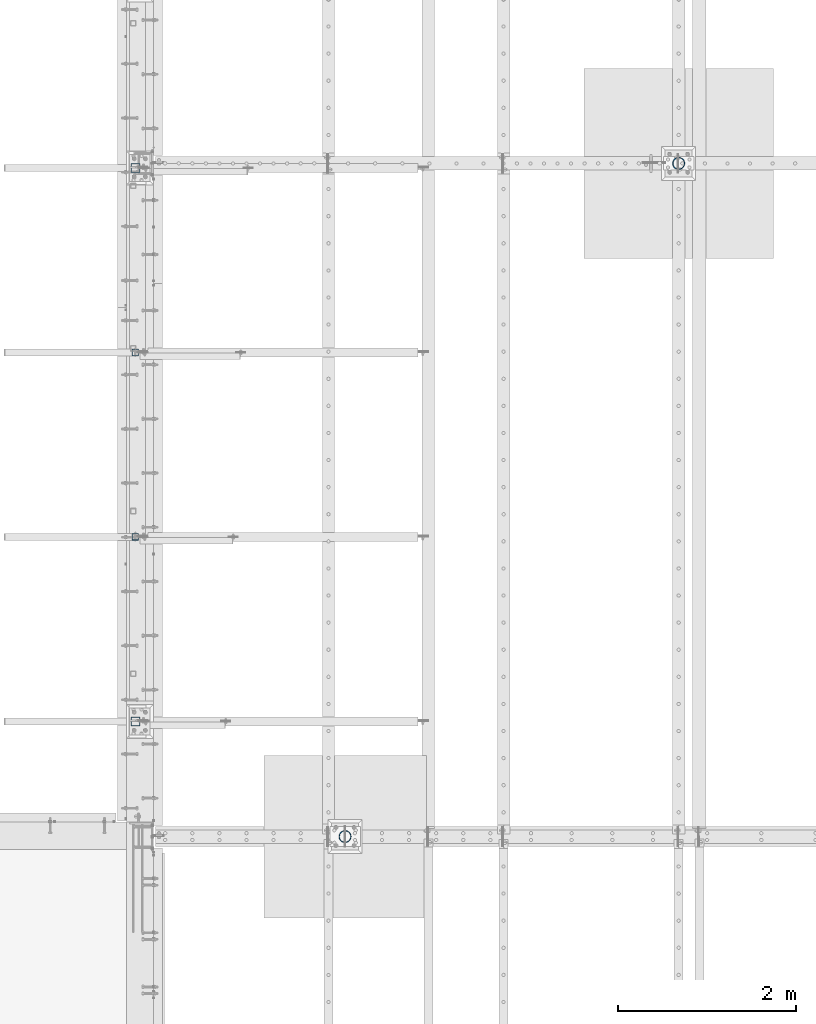
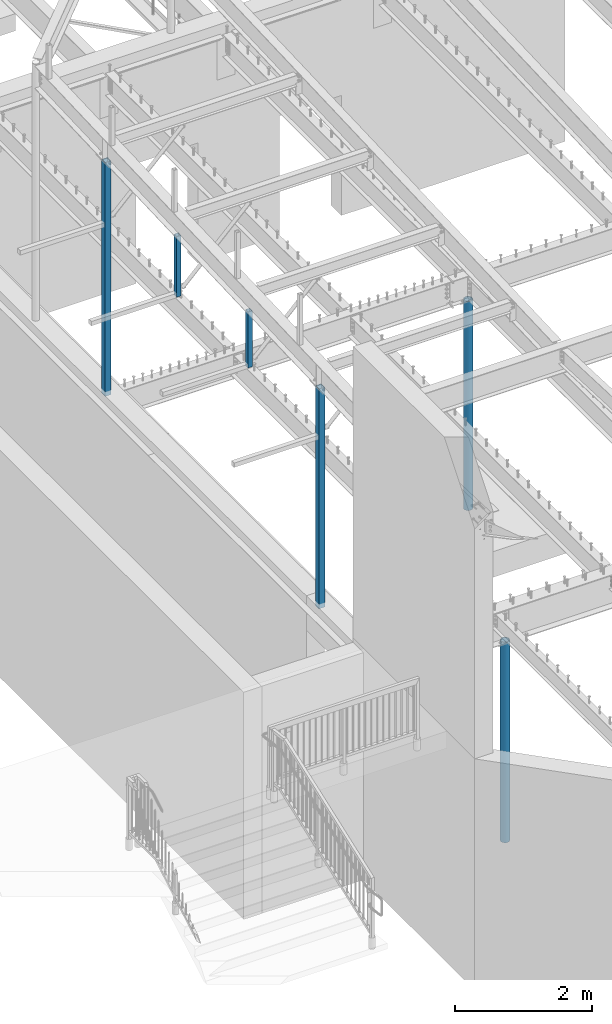
# One storey, part 121 of 975: 6 columns.
"""IFC2X3 building model written with IfcOpenShell, lengths in millimetres."""

from ifc_helpers import new_model, si_unit, frame, origin_with_axes, place, context, subcontext, project, spatial, faceted_brep, material, type_object, element, save


model = new_model("IFC2X3")

# Units and contexts
model_context = context("Model", 3, precision=1e-05, world=origin_with_axes())
body_context = subcontext(model_context, "Body", "Model", "MODEL_VIEW")
ifc_project = project(units=[si_unit("LENGTHUNIT", "METRE", prefix="MILLI"), si_unit("AREAUNIT", "SQUARE_METRE"), si_unit("VOLUMEUNIT", "CUBIC_METRE"), si_unit("MASSUNIT", "GRAM", prefix="KILO"), si_unit("TIMEUNIT", "SECOND"), si_unit("PLANEANGLEUNIT", "RADIAN"), si_unit("SOLIDANGLEUNIT", "STERADIAN"), si_unit("THERMODYNAMICTEMPERATUREUNIT", "DEGREE_CELSIUS"), si_unit("LUMINOUSINTENSITYUNIT", "LUMEN")], contexts=[model_context])

# Site, building, storey
site_placement = place(None, origin_with_axes())
site = spatial("IfcSite", under=ifc_project, at=site_placement, CompositionType="ELEMENT")
building_placement = place(site_placement, origin_with_axes())
building = spatial("IfcBuilding", under=site, at=building_placement, Name="Undefined", CompositionType="ELEMENT")
storey_placement = place(building_placement, origin_with_axes())
storey = spatial("IfcBuildingStorey", under=building, at=storey_placement, Name="Undefined", CompositionType="ELEMENT", Elevation=0.0)

# Columns
ifc_material_1 = material()
column_type_1 = type_object("IfcColumnType", Name="HSS3X3X1/4", PredefinedType="NOTDEFINED")
column_1_placement = place(storey_placement, frame((2117.725, 9190.56666666666, 6959.6), z_axis=(1.0, 0.0, 0.0), x_axis=(0.0, 0.0, 1.0)))
element("IfcColumn", 1, at=column_1_placement, inside=storey, type_object=column_type_1, material=ifc_material_1, ObjectType="HSS3X3X1/4", context=body_context, shape_type="Brep", body=[
    faceted_brep([(6.35000000000127, -38.1000000000004, -38.0999999999999), (6.35000000000127, 38.1000000000004, -38.0999999999999), (999.106686584069, 38.1000000000004, -38.0999999999999), (1002.13967160395, -38.1000000000004, -38.0999999999999), (6.35000000000127, -38.1000000000004, 38.0999999999999), (1002.13967160395, -38.1000000000004, 38.0999999999999), (6.35000000000127, 38.1000000000004, 38.0999999999999), (999.106686584069, 38.1000000000004, 38.0999999999999), (6.35000000000127, 31.75, 31.75), (6.35000000000127, -31.75, 31.75), (6.35000000000127, -31.75, -31.75), (6.35000000000127, 31.75, -31.75), (1001.88692285229, -31.75, 31.75), (1001.88692285229, -31.75, -31.75), (999.359435335726, 31.75, -31.75), (999.359435335726, 31.75, 31.75)], [[[0, 1, 2, 3]], [[4, 0, 3, 5]], [[6, 4, 5, 7]], [[1, 6, 7, 2]], [[0, 4, 6, 1], [8, 9, 10, 11]], [[10, 9, 12, 13]], [[11, 10, 13, 14]], [[8, 11, 14, 15]], [[9, 8, 15, 12]], [[2, 7, 5, 3], [14, 13, 12, 15]]]),
])
column_2_placement = place(storey_placement, frame((2117.725, 11265.9583333333, 6959.6), z_axis=(1.0, 0.0, 0.0), x_axis=(0.0, 0.0, 1.0)))
element("IfcColumn", 2, at=column_2_placement, inside=storey, type_object=column_type_1, material=ifc_material_1, ObjectType="HSS3X3X1/4", context=body_context, shape_type="Brep", body=[
    faceted_brep([(6.35000000000127, -38.1000000000004, -38.0999999999999), (6.35000000000127, 38.1000000000004, -38.0999999999999), (1081.7134035839, 38.1000000000004, -38.0999999999999), (1084.74638860378, -38.1000000000004, -38.0999999999999), (6.35000000000127, -38.1000000000004, 38.0999999999999), (1084.74638860378, -38.1000000000004, 38.0999999999999), (6.35000000000127, 38.1000000000004, 38.0999999999999), (1081.7134035839, 38.1000000000004, 38.0999999999999), (6.35000000000127, 31.75, 31.75), (6.35000000000127, -31.75, 31.75), (6.35000000000127, -31.75, -31.75), (6.35000000000127, 31.75, -31.75), (1084.49363985213, -31.75, 31.75), (1084.49363985213, -31.75, -31.75), (1081.96615233556, 31.75, -31.75), (1081.96615233556, 31.75, 31.75)], [[[0, 1, 2, 3]], [[4, 0, 3, 5]], [[6, 4, 5, 7]], [[1, 6, 7, 2]], [[0, 4, 6, 1], [8, 9, 10, 11]], [[10, 9, 12, 13]], [[11, 10, 13, 14]], [[8, 11, 14, 15]], [[9, 8, 15, 12]], [[2, 7, 5, 3], [14, 13, 12, 15]]]),
])
column_type_2 = type_object("IfcColumnType", Name="HSS4X4X1/4", PredefinedType="NOTDEFINED")
column_3_placement = place(storey_placement, frame((2117.725, 13341.35, 3937.0), z_axis=(0.0, 1.0, 0.0), x_axis=(0.0, 0.0, 1.0)))
element("IfcColumn", 3, at=column_3_placement, inside=storey, type_object=column_type_2, material=ifc_material_1, Name="COLUMN", ObjectType="HSS4X4X1/4", context=body_context, shape_type="Brep", body=[
    faceted_brep([(19.0499999999988, 44.4499999999998, -44.4500000000007), (19.0499999999988, -44.4499999999998, -44.4500000000007), (4173.95731566356, -44.4499999999998, -44.4500000000007), (4173.95731566356, 44.4499999999998, -44.4500000000007), (19.0499999999988, -44.4499999999998, 44.4500000000007), (4177.49579818676, -44.4499999999998, 44.4500000000007), (19.0499999999988, 44.4499999999998, 44.4500000000007), (4177.49579818676, 44.4499999999998, 44.4500000000007), (19.0499999999988, 50.8000000000002, -50.7999999999993), (19.0499999999988, 50.8000000000002, 50.7999999999993), (4177.74854693841, 50.8000000000002, 50.7999999999993), (4173.70456691191, 50.8000000000002, -50.7999999999993), (19.0499999999988, -50.8000000000002, 50.7999999999993), (4177.74854693841, -50.8000000000002, 50.7999999999993), (19.0499999999988, -50.8000000000002, -50.7999999999993), (4173.70456691191, -50.8000000000002, -50.7999999999993)], [[[0, 1, 2, 3]], [[1, 4, 5, 2]], [[4, 6, 7, 5]], [[6, 0, 3, 7]], [[8, 9, 10, 11]], [[9, 12, 13, 10]], [[12, 14, 15, 13]], [[14, 8, 11, 15]], [[13, 15, 11, 10], [5, 7, 3, 2]], [[14, 12, 9, 8], [6, 4, 1, 0]]]),
])
column_4_placement = place(storey_placement, frame((2117.725, 7115.175, 3937.0), z_axis=(0.0, 1.0, 0.0), x_axis=(0.0, 0.0, 1.0)))
element("IfcColumn", 4, at=column_4_placement, inside=storey, type_object=column_type_2, material=ifc_material_1, Name="COLUMN", ObjectType="HSS4X4X1/4", context=body_context, shape_type="Brep", body=[
    faceted_brep([(19.0499999999988, 44.4499999999998, -44.4500000000007), (19.0499999999988, -44.4499999999998, -44.4500000000007), (3926.13716466218, -44.4499999999998, -44.4499999999998), (3926.13716466218, 44.4499999999998, -44.4499999999998), (19.0499999999988, -44.4499999999998, 44.4500000000007), (3929.67564718537, -44.4499999999998, 44.4499999999998), (19.0499999999988, 44.4499999999998, 44.4500000000007), (3929.67564718537, 44.4499999999998, 44.4499999999998), (19.0499999999988, 50.8000000000002, -50.7999999999993), (19.0499999999988, 50.8000000000002, 50.7999999999993), (3929.92839593703, 50.8000000000002, 50.8000000000002), (3925.88441591052, 50.8000000000002, -50.8000000000002), (19.0499999999988, -50.8000000000002, 50.7999999999993), (3929.92839593703, -50.8000000000002, 50.8000000000002), (19.0499999999988, -50.8000000000002, -50.7999999999993), (3925.88441591052, -50.8000000000002, -50.8000000000002)], [[[0, 1, 2, 3]], [[1, 4, 5, 2]], [[4, 6, 7, 5]], [[6, 0, 3, 7]], [[8, 9, 10, 11]], [[9, 12, 13, 10]], [[12, 14, 15, 13]], [[14, 8, 11, 15]], [[13, 15, 11, 10], [5, 7, 3, 2]], [[14, 12, 9, 8], [6, 4, 1, 0]]]),
])
ifc_material_2 = material(Name="STEEL/A53")
column_type_3 = type_object("IfcColumnType", Name="PIPE5XS", PredefinedType="NOTDEFINED")
column_5_placement = place(storey_placement, frame((4476.75, 5819.775, -266.7), z_axis=(0.0, 1.0, 0.0), x_axis=(0.0, 0.0, 1.0)))
element("IfcColumn", 5, at=column_5_placement, inside=storey, type_object=column_type_3, material=ifc_material_2, Name="COLUMN", ObjectType="PIPE5XS", context=body_context, shape_type="Brep", body=[
    faceted_brep([(25.3999999999999, -61.0869999999995, 0.0), (25.3999999999999, -58.0971894109207, 18.8769211353829), (3587.75, -58.0971894109216, 18.8769211353829), (3587.75, -61.0870000000004, 0.0), (25.3999999999999, -49.4204211353826, 35.9060377067908), (3587.75, -49.4204211353826, 35.9060377067899), (25.3999999999999, -35.9060377067908, 49.4204211353826), (3587.75, -35.9060377067899, 49.4204211353826), (25.3999999999999, -18.8769211353829, 58.0971894109225), (3587.75, -18.876921135382, 58.0971894109216), (25.3999999999999, 0.0, 61.0869999999995), (3587.75, 0.0, 61.0870000000004), (25.3999999999999, 18.8769211353829, 58.0971894109225), (3587.75, 18.8769211353829, 58.0971894109216), (25.3999999999999, 35.9060377067908, 49.4204211353826), (3587.75, 35.9060377067899, 49.4204211353826), (25.3999999999999, 49.4204211353826, 35.9060377067908), (3587.75, 49.4204211353826, 35.9060377067899), (25.3999999999999, 58.0971894109207, 18.8769211353829), (3587.75, 58.0971894109216, 18.876921135382), (25.3999999999999, 61.0869999999995, 0.0), (3587.75, 61.0870000000004, 0.0), (25.3999999999999, 58.0971894109207, -18.8769211353829), (3587.75, 58.0971894109216, -18.8769211353829), (25.3999999999999, 49.4204211353826, -35.9060377067908), (3587.75, 49.4204211353826, -35.9060377067899), (25.3999999999999, 35.9060377067908, -49.4204211353826), (3587.75, 35.9060377067899, -49.4204211353826), (25.3999999999999, 18.8769211353829, -58.0971894109225), (3587.75, 18.876921135382, -58.0971894109216), (25.3999999999999, 0.0, -61.0869999999995), (3587.75, 0.0, -61.0870000000004), (25.3999999999999, -18.8769211353829, -58.0971894109225), (3587.75, -18.876921135382, -58.0971894109216), (25.3999999999999, -35.9060377067908, -49.4204211353826), (3587.75, -35.9060377067899, -49.4204211353826), (25.3999999999999, -49.4204211353826, -35.9060377067908), (3587.75, -49.4204211353826, -35.9060377067899), (25.3999999999999, -58.0971894109207, -18.8769211353829), (3587.75, -58.0971894109216, -18.876921135382), (25.3999999999999, -70.612000000001, 0.0), (25.3999999999999, -67.1560027286323, -21.8203080068042), (3587.75, -67.1560027286332, -21.8203080068042), (3587.75, -70.6120000000001, 0.0), (25.3999999999999, -57.126308006802, -41.5046922348765), (3587.75, -57.1263080068038, -41.5046922348765), (25.3999999999999, -41.5046922348774, -57.1263080068038), (3587.75, -41.5046922348765, -57.1263080068038), (25.3999999999999, -21.8203080068051, -67.1560027286332), (3587.75, -21.8203080068033, -67.1560027286332), (25.3999999999999, 0.0, -70.6120000000001), (3587.75, 0.0, -70.6120000000001), (25.3999999999999, 21.8203080068051, -67.1560027286332), (3587.75, 21.8203080068042, -67.1560027286332), (25.3999999999999, 41.5046922348774, -57.1263080068038), (3587.75, 41.5046922348765, -57.1263080068038), (25.3999999999999, 57.126308006802, -41.5046922348765), (3587.75, 57.1263080068038, -41.5046922348765), (25.3999999999999, 67.1560027286323, -21.8203080068042), (3587.75, 67.1560027286332, -21.8203080068042), (25.3999999999999, 70.612000000001, 0.0), (3587.75, 70.6120000000001, 0.0), (25.3999999999999, 67.1560027286323, 21.8203080068042), (3587.75, 67.1560027286332, 21.8203080068042), (25.3999999999999, 57.126308006802, 41.5046922348765), (3587.75, 57.1263080068038, 41.5046922348765), (25.3999999999999, 41.5046922348774, 57.1263080068038), (3587.75, 41.5046922348765, 57.1263080068038), (25.3999999999999, 21.8203080068051, 67.1560027286332), (3587.75, 21.8203080068042, 67.1560027286332), (25.3999999999999, 0.0, 70.6120000000001), (3587.75, 0.0, 70.6120000000001), (25.3999999999999, -21.8203080068051, 67.1560027286332), (3587.75, -21.8203080068042, 67.1560027286332), (25.3999999999999, -41.5046922348774, 57.1263080068038), (3587.75, -41.5046922348765, 57.1263080068038), (25.3999999999999, -57.126308006802, 41.5046922348765), (3587.75, -57.1263080068038, 41.5046922348765), (25.3999999999999, -67.1560027286323, 21.8203080068042), (3587.75, -67.1560027286332, 21.8203080068042)], [[[0, 1, 2, 3]], [[1, 4, 5, 2]], [[4, 6, 7, 5]], [[6, 8, 9, 7]], [[8, 10, 11, 9]], [[10, 12, 13, 11]], [[12, 14, 15, 13]], [[14, 16, 17, 15]], [[16, 18, 19, 17]], [[18, 20, 21, 19]], [[20, 22, 23, 21]], [[22, 24, 25, 23]], [[24, 26, 27, 25]], [[26, 28, 29, 27]], [[28, 30, 31, 29]], [[30, 32, 33, 31]], [[32, 34, 35, 33]], [[34, 36, 37, 35]], [[36, 38, 39, 37]], [[38, 0, 3, 39]], [[40, 41, 42, 43]], [[41, 44, 45, 42]], [[44, 46, 47, 45]], [[46, 48, 49, 47]], [[48, 50, 51, 49]], [[50, 52, 53, 51]], [[52, 54, 55, 53]], [[54, 56, 57, 55]], [[56, 58, 59, 57]], [[58, 60, 61, 59]], [[60, 62, 63, 61]], [[62, 64, 65, 63]], [[64, 66, 67, 65]], [[66, 68, 69, 67]], [[68, 70, 71, 69]], [[70, 72, 73, 71]], [[72, 74, 75, 73]], [[74, 76, 77, 75]], [[76, 78, 79, 77]], [[78, 40, 43, 79]], [[45, 47, 49, 51, 53, 55, 57, 59, 61, 63, 65, 67, 69, 71, 73, 75, 77, 79, 43, 42], [5, 7, 9, 11, 13, 15, 17, 19, 21, 23, 25, 27, 29, 31, 33, 35, 37, 39, 3, 2]], [[78, 76, 74, 72, 70, 68, 66, 64, 62, 60, 58, 56, 54, 52, 50, 48, 46, 44, 41, 40], [38, 36, 34, 32, 30, 28, 26, 24, 22, 20, 18, 16, 14, 12, 10, 8, 6, 4, 1, 0]]]),
])
column_6_placement = place(storey_placement, frame((8229.6, 13392.15, -266.7), z_axis=(0.0, 1.0, 0.0), x_axis=(0.0, 0.0, 1.0)))
element("IfcColumn", 6, at=column_6_placement, inside=storey, type_object=column_type_3, material=ifc_material_2, Name="COLUMN", ObjectType="PIPE5XS", context=body_context, shape_type="Brep", body=[
    faceted_brep([(25.3999999999999, -61.0869999999995, 0.0), (25.3999999999999, -58.0971894109207, 18.8769211353829), (3740.15, -58.0971894109207, 18.8769211353829), (3740.15, -61.0869999999995, 0.0), (25.3999999999999, -49.4204211353826, 35.9060377067908), (3740.15, -49.4204211353826, 35.9060377067908), (25.3999999999999, -35.9060377067908, 49.4204211353826), (3740.15, -35.9060377067908, 49.4204211353826), (25.3999999999999, -18.8769211353829, 58.0971894109225), (3740.15, -18.8769211353829, 58.0971894109225), (25.3999999999999, 0.0, 61.0869999999995), (3740.15, 0.0, 61.0869999999995), (25.3999999999999, 18.8769211353829, 58.0971894109225), (3740.15, 18.8769211353829, 58.0971894109225), (25.3999999999999, 35.9060377067908, 49.4204211353826), (3740.15, 35.9060377067908, 49.4204211353826), (25.3999999999999, 49.4204211353826, 35.9060377067908), (3740.15, 49.4204211353826, 35.9060377067908), (25.3999999999999, 58.0971894109207, 18.8769211353829), (3740.15, 58.0971894109207, 18.8769211353829), (25.3999999999999, 61.0869999999995, 0.0), (3740.15, 61.0869999999995, 0.0), (25.3999999999999, 58.0971894109207, -18.8769211353829), (3740.15, 58.0971894109207, -18.8769211353829), (25.3999999999999, 49.4204211353826, -35.9060377067908), (3740.15, 49.4204211353826, -35.9060377067908), (25.3999999999999, 35.9060377067908, -49.4204211353826), (3740.15, 35.9060377067908, -49.4204211353826), (25.3999999999999, 18.8769211353829, -58.0971894109225), (3740.15, 18.8769211353829, -58.0971894109225), (25.3999999999999, 0.0, -61.0869999999995), (3740.15, 0.0, -61.0869999999995), (25.3999999999999, -18.8769211353829, -58.0971894109225), (3740.15, -18.8769211353829, -58.0971894109225), (25.3999999999999, -35.9060377067908, -49.4204211353826), (3740.15, -35.9060377067908, -49.4204211353826), (25.3999999999999, -49.4204211353826, -35.9060377067908), (3740.15, -49.4204211353826, -35.9060377067908), (25.3999999999999, -58.0971894109207, -18.8769211353829), (3740.15, -58.0971894109207, -18.8769211353829), (25.3999999999999, -70.612000000001, 0.0), (25.3999999999999, -67.1560027286323, -21.8203080068042), (3740.15, -67.1560027286323, -21.8203080068042), (3740.15, -70.612000000001, 0.0), (25.3999999999999, -57.126308006802, -41.5046922348765), (3740.15, -57.126308006802, -41.5046922348765), (25.3999999999999, -41.5046922348774, -57.1263080068038), (3740.15, -41.5046922348774, -57.1263080068038), (25.3999999999999, -21.8203080068051, -67.1560027286332), (3740.15, -21.8203080068051, -67.1560027286332), (25.3999999999999, 0.0, -70.6120000000001), (3740.15, 0.0, -70.6120000000001), (25.3999999999999, 21.8203080068051, -67.1560027286332), (3740.15, 21.8203080068051, -67.1560027286332), (25.3999999999999, 41.5046922348774, -57.1263080068038), (3740.15, 41.5046922348774, -57.1263080068038), (25.3999999999999, 57.126308006802, -41.5046922348765), (3740.15, 57.126308006802, -41.5046922348765), (25.3999999999999, 67.1560027286323, -21.8203080068042), (3740.15, 67.1560027286323, -21.8203080068042), (25.3999999999999, 70.612000000001, 0.0), (3740.15, 70.612000000001, 0.0), (25.3999999999999, 67.1560027286323, 21.8203080068042), (3740.15, 67.1560027286323, 21.8203080068042), (25.3999999999999, 57.126308006802, 41.5046922348765), (3740.15, 57.126308006802, 41.5046922348765), (25.3999999999999, 41.5046922348774, 57.1263080068038), (3740.15, 41.5046922348774, 57.1263080068038), (25.3999999999999, 21.8203080068051, 67.1560027286332), (3740.15, 21.8203080068051, 67.1560027286332), (25.3999999999999, 0.0, 70.6120000000001), (3740.15, 0.0, 70.6120000000001), (25.3999999999999, -21.8203080068051, 67.1560027286332), (3740.15, -21.8203080068051, 67.1560027286332), (25.3999999999999, -41.5046922348774, 57.1263080068038), (3740.15, -41.5046922348774, 57.1263080068038), (25.3999999999999, -57.126308006802, 41.5046922348765), (3740.15, -57.126308006802, 41.5046922348765), (25.3999999999999, -67.1560027286323, 21.8203080068042), (3740.15, -67.1560027286323, 21.8203080068042)], [[[0, 1, 2, 3]], [[1, 4, 5, 2]], [[4, 6, 7, 5]], [[6, 8, 9, 7]], [[8, 10, 11, 9]], [[10, 12, 13, 11]], [[12, 14, 15, 13]], [[14, 16, 17, 15]], [[16, 18, 19, 17]], [[18, 20, 21, 19]], [[20, 22, 23, 21]], [[22, 24, 25, 23]], [[24, 26, 27, 25]], [[26, 28, 29, 27]], [[28, 30, 31, 29]], [[30, 32, 33, 31]], [[32, 34, 35, 33]], [[34, 36, 37, 35]], [[36, 38, 39, 37]], [[38, 0, 3, 39]], [[40, 41, 42, 43]], [[41, 44, 45, 42]], [[44, 46, 47, 45]], [[46, 48, 49, 47]], [[48, 50, 51, 49]], [[50, 52, 53, 51]], [[52, 54, 55, 53]], [[54, 56, 57, 55]], [[56, 58, 59, 57]], [[58, 60, 61, 59]], [[60, 62, 63, 61]], [[62, 64, 65, 63]], [[64, 66, 67, 65]], [[66, 68, 69, 67]], [[68, 70, 71, 69]], [[70, 72, 73, 71]], [[72, 74, 75, 73]], [[74, 76, 77, 75]], [[76, 78, 79, 77]], [[78, 40, 43, 79]], [[45, 47, 49, 51, 53, 55, 57, 59, 61, 63, 65, 67, 69, 71, 73, 75, 77, 79, 43, 42], [5, 7, 9, 11, 13, 15, 17, 19, 21, 23, 25, 27, 29, 31, 33, 35, 37, 39, 3, 2]], [[78, 76, 74, 72, 70, 68, 66, 64, 62, 60, 58, 56, 54, 52, 50, 48, 46, 44, 41, 40], [38, 36, 34, 32, 30, 28, 26, 24, 22, 20, 18, 16, 14, 12, 10, 8, 6, 4, 1, 0]]]),
])

save(model, "model.ifc")
